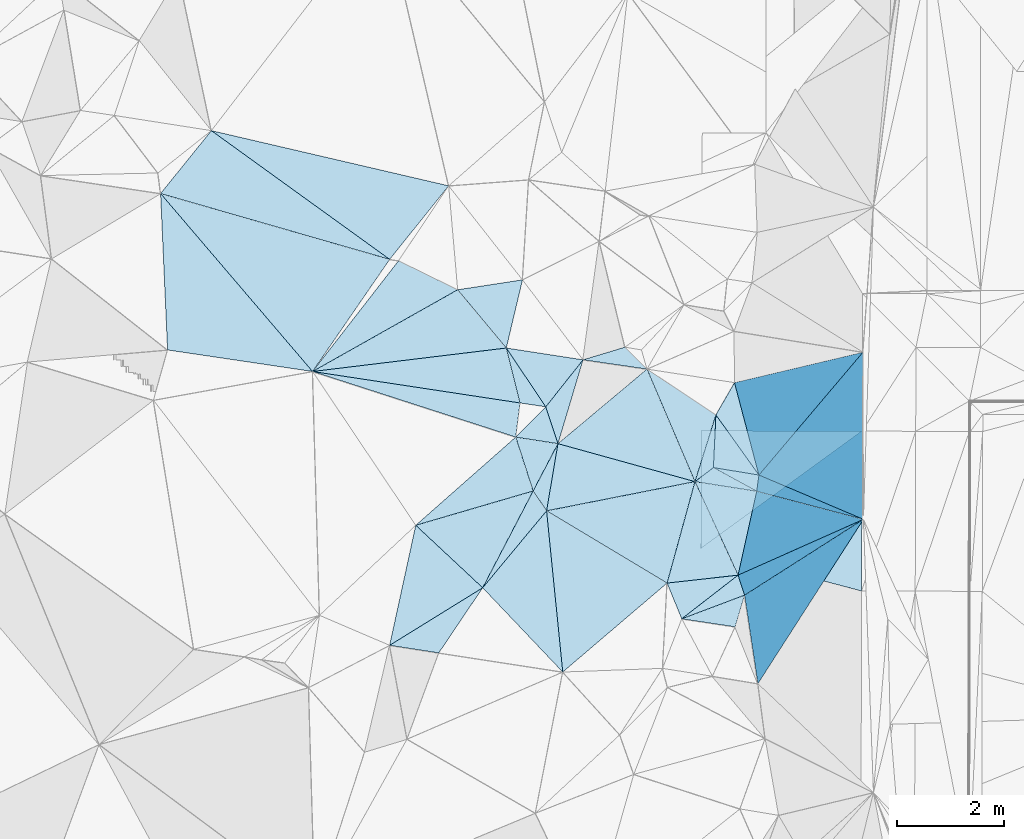
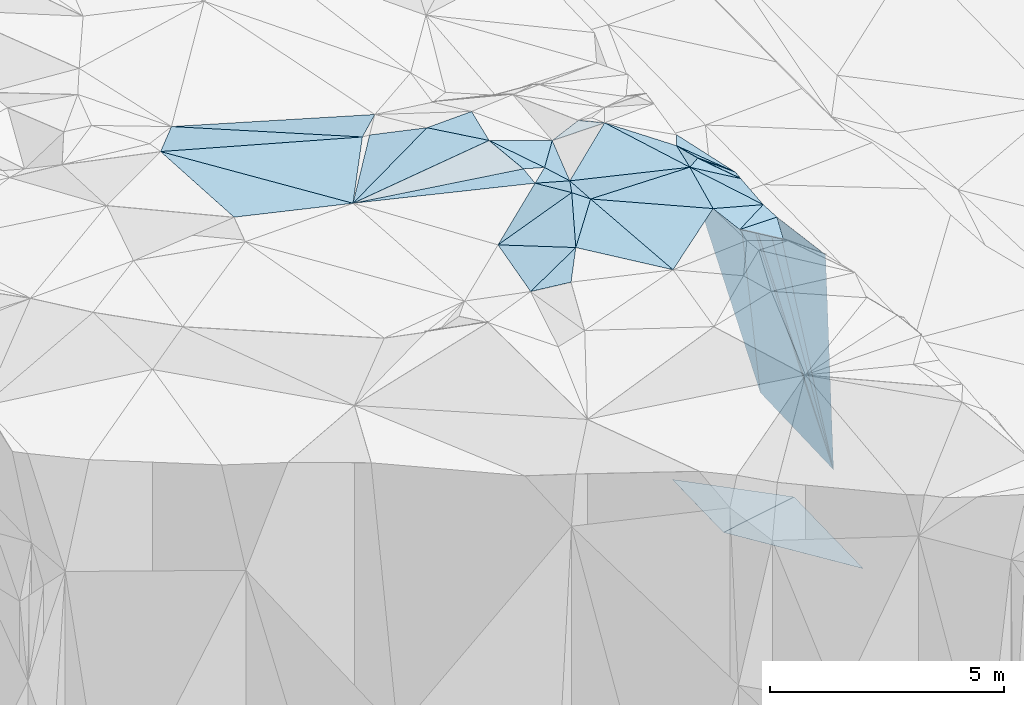
# One storey, part 125 of 275: 45 plates.
"""IFC2X3 building model written with IfcOpenShell, lengths in millimetres."""

import ifcopenshell
import ifcopenshell.guid

model = None  # the IFC model being written
_history = None  # IfcOwnerHistory: only IFC2X3 demands one
_inside = {}  # id of a spatial element -> (the spatial element, [elements in it])
_under = {}  # id of a project, library or spatial element -> (it, [spatial elements below it])
_declared = {}  # id of a project -> (the project, [libraries it declares])
_typed = {}  # id of a type object -> (the type object, [elements of that type])
_made_of = {}  # id of a material, layer set ... -> (it, [elements and type objects made of it])


def new_model(schema):
    """Start an empty IFC model of exactly this schema.

    Asked for "IFC4X3", IfcOpenShell would pick the latest addendum, in which some entities
    have other attributes; the version numbers below select the first issue.
    IFC2X3 requires an IfcOwnerHistory on every rooted entity: one is made here for all.
    """
    global model, _history
    if schema == "IFC4X3":
        model = ifcopenshell.file(schema_version=(4, 3, 0, 0))
    else:
        model = ifcopenshell.file(schema=schema)
    _inside.clear()
    _under.clear()
    _declared.clear()
    _typed.clear()
    _made_of.clear()
    _history = None
    if model.schema == "IFC2X3":
        org = make("IfcOrganization", Name="unknown")
        user = make(
            "IfcPersonAndOrganization",
            ThePerson=make("IfcPerson", FamilyName="unknown"),
            TheOrganization=org,
        )
        app = make(
            "IfcApplication",
            ApplicationDeveloper=org,
            Version="unknown",
            ApplicationFullName="unknown",
            ApplicationIdentifier="unknown",
        )
        _history = make(
            "IfcOwnerHistory",
            OwningUser=user,
            OwningApplication=app,
            ChangeAction="ADDED",
            CreationDate=0,
        )
    return model


def make(cls, **values):
    """One entity of the class cls with the attributes given. An attribute that is None is left unset."""
    return model.create_entity(
        cls, **{name: value for name, value in values.items() if value is not None}
    )


def rooted(cls, **values):
    """An entity with a GlobalId (a new one), such as an element, a storey or a relation."""
    return make(cls, GlobalId=ifcopenshell.guid.new(), OwnerHistory=_history, **values)


def si_unit(unit_type, name, prefix=None):
    """IfcSIUnit, for example si_unit("LENGTHUNIT", "METRE", prefix="MILLI")."""
    return make("IfcSIUnit", UnitType=unit_type, Prefix=prefix, Name=name)


def assignment(units):
    """IfcUnitAssignment: the units of a project."""
    return None if units is None else make("IfcUnitAssignment", Units=units)


def point(xyz):
    """IfcCartesianPoint."""
    return None if xyz is None else make("IfcCartesianPoint", Coordinates=xyz)


def direction(xyz):
    """IfcDirection."""
    return None if xyz is None else make("IfcDirection", DirectionRatios=xyz)


def frame(location, z_axis=None, x_axis=None):
    """IfcAxis2Placement3D, a coordinate frame: its origin and axes. An axis left out is left unset."""
    return make(
        "IfcAxis2Placement3D",
        Location=point(location),
        Axis=direction(z_axis),
        RefDirection=direction(x_axis),
    )


def origin_with_axes():
    """The frame at (0, 0, 0) with the z axis (0, 0, 1) and the x axis (1, 0, 0) written out."""
    return frame((0.0, 0.0, 0.0), z_axis=(0.0, 0.0, 1.0), x_axis=(1.0, 0.0, 0.0))


def place(relative_to, where):
    """IfcLocalPlacement: puts the frame where relative to a parent placement (None: the world)."""
    return make(
        "IfcLocalPlacement", PlacementRelTo=relative_to, RelativePlacement=where
    )


def context(
    kind, dimensions, precision=None, world=None, true_north=None, identifier=None
):
    """IfcGeometricRepresentationContext, for example the 3D "Model" context."""
    return make(
        "IfcGeometricRepresentationContext",
        ContextIdentifier=identifier,
        ContextType=kind,
        CoordinateSpaceDimension=dimensions,
        Precision=precision,
        WorldCoordinateSystem=world,
        TrueNorth=true_north,
    )


def subcontext(parent, identifier, kind, view, scale=None):
    """IfcGeometricRepresentationSubContext, for example "Body" below "Model"."""
    return make(
        "IfcGeometricRepresentationSubContext",
        ContextIdentifier=identifier,
        ContextType=kind,
        ParentContext=parent,
        TargetScale=scale,
        TargetView=view,
    )


def project(units=None, contexts=None):
    """IfcProject with its units and contexts."""
    return rooted(
        "IfcProject",
        Name="project",
        RepresentationContexts=contexts,
        UnitsInContext=assignment(units),
    )


def spatial(cls, under=None, at=None, **own):
    """A site, building, storey or space (cls), placed at a placement, below another one or the project."""
    s = rooted(cls, ObjectPlacement=at, **own)
    if under is not None:
        _under.setdefault(under.id(), (under, []))[1].append(s)
    return s


def polyline(points):
    """IfcPolyline through the points."""
    return make("IfcPolyline", Points=[point(p) for p in points])


def outline(outer, holes=None, kind="AREA"):
    """IfcArbitraryClosedProfileDef: a profile drawn as a closed curve; with holes, ...WithVoids."""
    if holes is None:
        return make("IfcArbitraryClosedProfileDef", ProfileType=kind, OuterCurve=outer)
    return make(
        "IfcArbitraryProfileDefWithVoids",
        ProfileType=kind,
        OuterCurve=outer,
        InnerCurves=holes,
    )


def extrude(swept, where, along, depth):
    """IfcExtrudedAreaSolid: the profile swept, set in the frame where, extruded along a direction by depth."""
    return make(
        "IfcExtrudedAreaSolid",
        SweptArea=swept,
        Position=where,
        ExtrudedDirection=direction(along),
        Depth=depth,
    )


def shape(context_of_items, identifier, shape_type, items):
    """IfcShapeRepresentation: the items that make up one representation, for example the "Body"."""
    return make(
        "IfcShapeRepresentation",
        ContextOfItems=context_of_items,
        RepresentationIdentifier=identifier,
        RepresentationType=shape_type,
        Items=items,
    )


def material(Name=None, Category=None):
    """IfcMaterial."""
    return make("IfcMaterial", Name=Name, Category=Category)


def made_of(thing, what):
    """Note that an element or type object is made of a material, layer set ...; save() writes the relation."""
    if what is not None:
        _made_of.setdefault(what.id(), (what, []))[1].append(thing)
    return thing


def type_object(cls, material=None, **own):
    """A type object (cls), such as IfcWallType, which elements share."""
    return made_of(rooted(cls, **own), material)


def element(
    cls,
    number,
    at=None,
    inside=None,
    cuts=None,
    type_object=None,
    material=None,
    context=None,
    identifier="Body",
    shape_type=None,
    held_by="IfcProductDefinitionShape",
    body=None,
    shapes=None,
    **own,
):
    """One element of the class cls, such as IfcWall. Its Tag is "e" and its number.

    at: its placement. inside: the storey or other place that contains it. cuts: it is an
    opening in that element (IfcRelVoidsElement). A single representation is given by context,
    identifier, shape_type and body (its items); several are given by shapes. held_by: the class
    of the entity that holds the representations. save() writes the other relations.
    """
    e = rooted(cls, Tag="e%d" % number, ObjectPlacement=at, **own)
    if body is not None:
        shapes = [shape(context, identifier, shape_type, body)]
    if shapes is not None:
        e.Representation = make(held_by, Representations=shapes)
    if inside is not None:
        _inside.setdefault(inside.id(), (inside, []))[1].append(e)
    if cuts is not None:
        rooted(
            "IfcRelVoidsElement", RelatingBuildingElement=cuts, RelatedOpeningElement=e
        )
    if type_object is not None:
        _typed.setdefault(type_object.id(), (type_object, []))[1].append(e)
    return made_of(e, material)


def aggregate(whole, parts):
    """IfcRelAggregates: a whole, such as a stair, and the parts it consists of."""
    return rooted("IfcRelAggregates", RelatingObject=whole, RelatedObjects=parts)


def save(model, path):
    """Write the relations noted so far, then the file.

    IfcRelAggregates (storeys below a building ...), IfcRelContainedInSpatialStructure (elements
    in a storey), IfcRelDefinesByType, IfcRelAssociatesMaterial and IfcRelDeclares: one each for
    every whole, place, type object, material and project.
    """
    for whole, parts in _under.values():
        aggregate(whole, parts)
    for where, things in _inside.values():
        rooted(
            "IfcRelContainedInSpatialStructure",
            RelatedElements=things,
            RelatingStructure=where,
        )
    for kind, things in _typed.values():
        rooted("IfcRelDefinesByType", RelatedObjects=things, RelatingType=kind)
    for what, things in _made_of.values():
        rooted("IfcRelAssociatesMaterial", RelatedObjects=things, RelatingMaterial=what)
    for by, libraries in _declared.values():
        rooted("IfcRelDeclares", RelatingContext=by, RelatedDefinitions=libraries)
    model.write(path)


model = new_model("IFC2X3")

# Units and contexts
model_context = context("Model", 3, precision=1e-05, world=origin_with_axes())
body_context = subcontext(model_context, "Body", "Model", "MODEL_VIEW")
ifc_project = project(units=[si_unit("LENGTHUNIT", "METRE", prefix="MILLI"), si_unit("AREAUNIT", "SQUARE_METRE"), si_unit("VOLUMEUNIT", "CUBIC_METRE"), si_unit("MASSUNIT", "GRAM", prefix="KILO"), si_unit("TIMEUNIT", "SECOND"), si_unit("PLANEANGLEUNIT", "RADIAN"), si_unit("SOLIDANGLEUNIT", "STERADIAN"), si_unit("THERMODYNAMICTEMPERATUREUNIT", "DEGREE_CELSIUS"), si_unit("LUMINOUSINTENSITYUNIT", "LUMEN")], contexts=[model_context])

# Site, building, storey
site_placement = place(None, origin_with_axes())
site = spatial("IfcSite", under=ifc_project, at=site_placement, CompositionType="ELEMENT")
building_placement = place(site_placement, origin_with_axes())
building = spatial("IfcBuilding", under=site, at=building_placement, Name="Undefined", CompositionType="ELEMENT")
storey_placement = place(building_placement, origin_with_axes())
storey = spatial("IfcBuildingStorey", under=building, at=storey_placement, Name="Undefined", CompositionType="ELEMENT", Elevation=0.0)

# Plates
ifc_material = material()
plate_type_1 = type_object("IfcPlateType", PredefinedType="NOTDEFINED")
plate_1_placement = place(storey_placement, frame((-101052.780690748, 99922.7773214752, 52409.8605869803), z_axis=(-0.951314452052336, -0.131450359193629, -0.278785968772155), x_axis=(0.256539233213614, 0.163673763012203, -0.952574680076894)))
element("IfcPlate", 1, at=plate_1_placement, inside=storey, type_object=plate_type_1, material=ifc_material, Name="00", context=body_context, shape_type="SweptSolid", body=[
    extrude(outline(polyline([(0.0, 0.0), (8636.5927734375, 2.459273673594e-08), (-139.684707641602, 1664.65856933594), (0.0, 0.0)])), frame((-8.85201319254618e-08, 2.18876761149539e-07, -0.5000001331573), z_axis=(0.0, 0.0, 1.0), x_axis=(1.0, 0.0, 0.0)), (0.0, 0.0, 1.0), 1.0),
])
plate_type_2 = type_object("IfcPlateType", PredefinedType="NOTDEFINED")
plate_2_placement = place(storey_placement, frame((-104994.24122469, 101864.670327626, 53249.5349262964), z_axis=(-0.212168563127397, -0.299815386676256, -0.930104958987223), x_axis=(-0.298590957240027, 0.926146234164656, -0.230426980184854)))
element("IfcPlate", 2, at=plate_2_placement, inside=storey, type_object=plate_type_2, material=ifc_material, Name="00", context=body_context, shape_type="SweptSolid", body=[
    extrude(outline(polyline([(0.0, 0.0), (1084.9423828125, 3.97267285734415e-09), (768.980895996094, 744.021728515625), (0.0, 0.0)])), frame((-8.85201319254618e-08, 2.18876761149539e-07, -0.5000001331573), z_axis=(0.0, 0.0, 1.0), x_axis=(1.0, 0.0, 0.0)), (0.0, 0.0, 1.0), 1.0),
])
plate_type_3 = type_object("IfcPlateType", PredefinedType="NOTDEFINED")
plate_3_placement = place(storey_placement, frame((-101869.450552332, 100790.557702751, 43940.43084673), z_axis=(-0.446999946643608, 0.0202267611373366, -0.894305275526487), x_axis=(0.752863457786508, 0.548428639948646, -0.363899217935159)))
element("IfcPlate", 3, at=plate_3_placement, inside=storey, type_object=plate_type_3, material=ifc_material, Name="00_PR", context=body_context, shape_type="SweptSolid", body=[
    extrude(outline(polyline([(0.0, 0.0), (3993.99047851563, 1.00699253380299e-08), (2375.33764648438, 2503.42431640625), (0.0, 0.0)])), frame((-8.85201319254618e-08, 2.18876761149539e-07, -0.5000001331573), z_axis=(0.0, 0.0, 1.0), x_axis=(1.0, 0.0, 0.0)), (0.0, 0.0, 1.0), 1.0),
])
plate_type_4 = type_object("IfcPlateType", PredefinedType="NOTDEFINED")
plate_4_placement = place(storey_placement, frame((-98862.5211300744, 102980.976509109, 42487.0208652084), z_axis=(-0.447068690798369, 0.0203457226282228, -0.89426821327752), x_axis=(-0.752863457790124, -0.548428639944787, 0.363899217933496)))
element("IfcPlate", 4, at=plate_4_placement, inside=storey, type_object=plate_type_4, material=ifc_material, Name="00_PR", context=body_context, shape_type="SweptSolid", body=[
    extrude(outline(polyline([(0.0, 0.0), (3993.99047851563, 1.00699253380299e-08), (2798.93188476563, 1848.23657226563), (0.0, 0.0)])), frame((-8.85201319254618e-08, 2.18876761149539e-07, -0.5000001331573), z_axis=(0.0, 0.0, 1.0), x_axis=(1.0, 0.0, 0.0)), (0.0, 0.0, 1.0), 1.0),
])
plate_type_5 = type_object("IfcPlateType", PredefinedType="NOTDEFINED")
plate_5_placement = place(storey_placement, frame((-107503.732634978, 106156.509016876, 53029.5030335635), z_axis=(0.0797627524604292, -0.0763591974138967, -0.993884890865256), x_axis=(0.892994833749772, -0.437578966658428, 0.105284732199688)))
element("IfcPlate", 5, at=plate_5_placement, inside=storey, type_object=plate_type_5, material=ifc_material, Name="00", context=body_context, shape_type="SweptSolid", body=[
    extrude(outline(polyline([(0.0, 0.0), (1234.74694824219, 2.16095941141248e-09), (-524.39892578125, 2559.98168945313), (0.0, 0.0)])), frame((-8.85201319254618e-08, 2.18876761149539e-07, -0.5000001331573), z_axis=(0.0, 0.0, 1.0), x_axis=(1.0, 0.0, 0.0)), (0.0, 0.0, 1.0), 1.0),
])
plate_type_6 = type_object("IfcPlateType", PredefinedType="NOTDEFINED")
plate_6_placement = place(storey_placement, frame((-102224.035636845, 99481.5333964225, 52759.5390734306), z_axis=(-0.335199629731002, 0.19468919551731, -0.921811979406333), x_axis=(-0.359367242240399, 0.878023109871996, 0.31611802184507)))
element("IfcPlate", 6, at=plate_6_placement, inside=storey, type_object=plate_type_6, material=ifc_material, Name="00", context=body_context, shape_type="SweptSolid", body=[
    extrude(outline(polyline([(0.0, 0.0), (759.210144042969, -6.40284270048141e-10), (271.071197509766, 1317.99865722656), (0.0, 0.0)])), frame((-8.85201319254618e-08, 2.18876761149539e-07, -0.5000001331573), z_axis=(0.0, 0.0, 1.0), x_axis=(1.0, 0.0, 0.0)), (0.0, 0.0, 1.0), 1.0),
])
plate_type_7 = type_object("IfcPlateType", PredefinedType="NOTDEFINED")
plate_7_placement = place(storey_placement, frame((-102496.778177613, 100147.995579476, 52999.5076277921), z_axis=(-0.149795645728894, -0.08900205802157, -0.984702949212903), x_axis=(-0.854670124604389, 0.512379459087029, 0.0837034528224651)))
element("IfcPlate", 7, at=plate_7_placement, inside=storey, type_object=plate_type_7, material=ifc_material, Name="00", context=body_context, shape_type="SweptSolid", body=[
    extrude(outline(polyline([(0.0, 0.0), (2628.32641601563, 1.01426849141717e-08), (504.275268554688, 1912.12097167969), (0.0, 0.0)])), frame((-8.85201319254618e-08, 2.18876761149539e-07, -0.5000001331573), z_axis=(0.0, 0.0, 1.0), x_axis=(1.0, 0.0, 0.0)), (0.0, 0.0, 1.0), 1.0),
])
plate_type_8 = type_object("IfcPlateType", PredefinedType="NOTDEFINED")
plate_8_placement = place(storey_placement, frame((-105494.585301776, 104530.038624328, 53169.502956674), z_axis=(-0.0790090593919938, -0.0750989410797683, -0.994041104573996), x_axis=(-0.640777609202176, 0.767694014892203, -0.00706788821592721)))
element("IfcPlate", 8, at=plate_8_placement, inside=storey, type_object=plate_type_8, material=ifc_material, Name="00", context=body_context, shape_type="SweptSolid", body=[
    extrude(outline(polyline([(0.0, 0.0), (1414.84985351563, 1.13250280264765e-08), (782.768615722656, 1052.31811523438), (0.0, 0.0)])), frame((-8.85201319254618e-08, 2.18876761149539e-07, -0.5000001331573), z_axis=(0.0, 0.0, 1.0), x_axis=(1.0, 0.0, 0.0)), (0.0, 0.0, 1.0), 1.0),
])
plate_type_9 = type_object("IfcPlateType", PredefinedType="NOTDEFINED")
plate_9_placement = place(storey_placement, frame((-111939.461162771, 107410.06796145, 53389.5039888158), z_axis=(-0.126114466030531, -0.00903749497429484, -0.991974528474609), x_axis=(0.647584047866844, -0.758252184458206, -0.0754223157477399)))
element("IfcPlate", 9, at=plate_9_placement, inside=storey, type_object=plate_type_9, material=ifc_material, Name="00", context=body_context, shape_type="SweptSolid", body=[
    extrude(outline(polyline([(0.0, 0.0), (4375.36279296875, -2.80888343695551e-08), (2294.9638671875, 1804.228515625), (0.0, 0.0)])), frame((-8.85201319254618e-08, 2.18876761149539e-07, -0.5000001331573), z_axis=(0.0, 0.0, 1.0), x_axis=(1.0, 0.0, 0.0)), (0.0, 0.0, 1.0), 1.0),
])
plate_type_10 = type_object("IfcPlateType", PredefinedType="NOTDEFINED")
plate_10_placement = place(storey_placement, frame((-101633.779482135, 102300.81086515, 52709.6041006973), z_axis=(-0.574917464161939, -0.20637256247792, -0.791757712218772), x_axis=(0.0454362008343763, 0.958123261541765, -0.282728433919032)))
element("IfcPlate", 10, at=plate_10_placement, inside=storey, type_object=plate_type_10, material=ifc_material, Name="00", context=body_context, shape_type="SweptSolid", body=[
    extrude(outline(polyline([(0.0, 0.0), (1025.71923828125, -6.51925802230835e-09), (69.6096878051758, 1034.82104492188), (0.0, 0.0)])), frame((-8.85201319254618e-08, 2.18876761149539e-07, -0.5000001331573), z_axis=(0.0, 0.0, 1.0), x_axis=(1.0, 0.0, 0.0)), (0.0, 0.0, 1.0), 1.0),
])
plate_type_11 = type_object("IfcPlateType", PredefinedType="NOTDEFINED")
plate_11_placement = place(storey_placement, frame((-104531.476450295, 102747.258094401, 52859.5017772124), z_axis=(-0.0837255023068137, -0.0131773066483509, -0.996401725637289), x_axis=(-0.313913232321636, 0.949351054200828, 0.0138223898497727)))
element("IfcPlate", 11, at=plate_11_placement, inside=storey, type_object=plate_type_11, material=ifc_material, Name="00", context=body_context, shape_type="SweptSolid", body=[
    extrude(outline(polyline([(0.0, 0.0), (723.4638671875, 1.13504938781261e-09), (1335.79577636719, 938.322814941406), (0.0, 0.0)])), frame((-8.85201319254618e-08, 2.18876761149539e-07, -0.5000001331573), z_axis=(0.0, 0.0, 1.0), x_axis=(1.0, 0.0, 0.0)), (0.0, 0.0, 1.0), 1.0),
])
plate_type_12 = type_object("IfcPlateType", PredefinedType="NOTDEFINED")
plate_12_placement = place(storey_placement, frame((-101977.38174001, 102039.812686806, 52749.5751020443), z_axis=(-0.378138741239032, 0.367324224747449, -0.849755262583202), x_axis=(0.792686433825307, 0.60260897713417, -0.0922531208503361)))
element("IfcPlate", 12, at=plate_12_placement, inside=storey, type_object=plate_type_12, material=ifc_material, Name="00", context=body_context, shape_type="SweptSolid", body=[
    extrude(outline(polyline([(0.0, 0.0), (433.589660644531, 4.94765117764473e-10), (858.415283203125, 984.1357421875), (0.0, 0.0)])), frame((-8.85201319254618e-08, 2.18876761149539e-07, -0.5000001331573), z_axis=(0.0, 0.0, 1.0), x_axis=(1.0, 0.0, 0.0)), (0.0, 0.0, 1.0), 1.0),
])
plate_type_13 = type_object("IfcPlateType", PredefinedType="NOTDEFINED")
plate_13_placement = place(storey_placement, frame((-109106.00025106, 104092.414857728, 53059.5011305136), z_axis=(-0.0346489017911542, -0.0583777233492858, -0.99769308658586), x_axis=(0.988378057486554, -0.149852085824833, -0.0255571487661035)))
element("IfcPlate", 13, at=plate_13_placement, inside=storey, type_object=plate_type_13, material=ifc_material, Name="00", context=body_context, shape_type="SweptSolid", body=[
    extrude(outline(polyline([(0.0, 0.0), (3912.79956054688, 2.66300048679113e-08), (3928.64501953125, 642.455383300781), (0.0, 0.0)])), frame((-8.85201319254618e-08, 2.18876761149539e-07, -0.5000001331573), z_axis=(0.0, 0.0, 1.0), x_axis=(1.0, 0.0, 0.0)), (0.0, 0.0, 1.0), 1.0),
])
plate_type_14 = type_object("IfcPlateType", PredefinedType="NOTDEFINED")
plate_14_placement = place(storey_placement, frame((-102224.062448541, 99481.6157136227, 52759.5758023473), z_axis=(-0.388823327787843, 0.359321869782455, -0.848353825749627), x_axis=(0.901228972809753, 0.339553887122981, -0.269238734783743)))
element("IfcPlate", 14, at=plate_14_placement, inside=storey, type_object=plate_type_14, material=ifc_material, Name="00", context=body_context, shape_type="SweptSolid", body=[
    extrude(outline(polyline([(0.0, 0.0), (1299.96154785156, 5.86442183703184e-09), (986.413818359375, 558.110961914063), (0.0, 0.0)])), frame((-8.85201319254618e-08, 2.18876761149539e-07, -0.5000001331573), z_axis=(0.0, 0.0, 1.0), x_axis=(1.0, 0.0, 0.0)), (0.0, 0.0, 1.0), 1.0),
])
plate_type_15 = type_object("IfcPlateType", PredefinedType="NOTDEFINED")
plate_15_placement = place(storey_placement, frame((-101052.773853434, 99922.7445325661, 52409.8567941893), z_axis=(-0.937641662662594, -0.197026935081731, -0.286371261287906), x_axis=(-0.290924103235318, 0.89569218685578, 0.336301460838689)))
element("IfcPlate", 15, at=plate_15_placement, inside=storey, type_object=plate_type_15, material=ifc_material, Name="00", context=body_context, shape_type="SweptSolid", body=[
    extrude(outline(polyline([(0.0, 0.0), (416.293151855469, -2.43380782194436e-09), (-2145.19506835938, 8365.935546875), (0.0, 0.0)])), frame((-8.85201319254618e-08, 2.18876761149539e-07, -0.5000001331573), z_axis=(0.0, 0.0, 1.0), x_axis=(1.0, 0.0, 0.0)), (0.0, 0.0, 1.0), 1.0),
])
plate_type_16 = type_object("IfcPlateType", PredefinedType="NOTDEFINED")
plate_16_placement = place(storey_placement, frame((-104743.251040852, 101494.644306304, 53219.5500320132), z_axis=(-0.391308095538949, -0.192533484965733, -0.899893789028811), x_axis=(-0.560172426310613, 0.82566761601673, 0.0669316118327603)))
element("IfcPlate", 16, at=plate_16_placement, inside=storey, type_object=plate_type_16, material=ifc_material, Name="00", context=body_context, shape_type="SweptSolid", body=[
    extrude(outline(polyline([(0.0, 0.0), (448.218688964844, -3.17231751978397e-09), (891.529052734375, 973.845947265625), (0.0, 0.0)])), frame((-8.85201319254618e-08, 2.18876761149539e-07, -0.5000001331573), z_axis=(0.0, 0.0, 1.0), x_axis=(1.0, 0.0, 0.0)), (0.0, 0.0, 1.0), 1.0),
])
plate_type_17 = type_object("IfcPlateType", PredefinedType="NOTDEFINED")
plate_17_placement = place(storey_placement, frame((-105494.625096528, 104530.156256097, 53169.5128459579), z_axis=(-0.158604122902922, 0.160170692423395, -0.974263866458571), x_axis=(0.543640945155846, -0.809538144781732, -0.221590872766479)))
element("IfcPlate", 17, at=plate_17_placement, inside=storey, type_object=plate_type_17, material=ifc_material, Name="00", context=body_context, shape_type="SweptSolid", body=[
    extrude(outline(polyline([(0.0, 0.0), (1353.84631347656, -5.37693267688155e-09), (1014.59075927734, 358.755645751953), (0.0, 0.0)])), frame((-8.85201319254618e-08, 2.18876761149539e-07, -0.5000001331573), z_axis=(0.0, 0.0, 1.0), x_axis=(1.0, 0.0, 0.0)), (0.0, 0.0, 1.0), 1.0),
])
plate_type_18 = type_object("IfcPlateType", PredefinedType="NOTDEFINED")
plate_18_placement = place(storey_placement, frame((-103282.006128294, 104546.055906759, 52909.504466475), z_axis=(0.129541275132308, 0.0330692780375528, -0.991022442171302), x_axis=(0.706664030143269, -0.704189176832656, 0.0688734472305546)))
element("IfcPlate", 18, at=plate_18_placement, inside=storey, type_object=plate_type_18, material=ifc_material, Name="00", context=body_context, shape_type="SweptSolid", body=[
    extrude(outline(polyline([(0.0, 0.0), (580.775329589844, -9.6588337328285e-10), (-393.439575195313, 723.467529296875), (0.0, 0.0)])), frame((-8.85201319254618e-08, 2.18876761149539e-07, -0.5000001331573), z_axis=(0.0, 0.0, 1.0), x_axis=(1.0, 0.0, 0.0)), (0.0, 0.0, 1.0), 1.0),
])
plate_type_19 = type_object("IfcPlateType", PredefinedType="NOTDEFINED")
plate_19_placement = place(storey_placement, frame((-104531.52556011, 102747.241751831, 52859.5088587508), z_axis=(-0.181941880242754, -0.0458598214129536, -0.982239293142818), x_axis=(-0.973182946861914, 0.151386964760187, 0.173196243717521)))
element("IfcPlate", 19, at=plate_19_placement, inside=storey, type_object=plate_type_19, material=ifc_material, Name="00", context=body_context, shape_type="SweptSolid", body=[
    extrude(outline(polyline([(0.0, 0.0), (808.331604003906, -4.86033968627453e-09), (326.722351074219, 645.486267089844), (0.0, 0.0)])), frame((-8.85201319254618e-08, 2.18876761149539e-07, -0.5000001331573), z_axis=(0.0, 0.0, 1.0), x_axis=(1.0, 0.0, 0.0)), (0.0, 0.0, 1.0), 1.0),
])
plate_type_20 = type_object("IfcPlateType", PredefinedType="NOTDEFINED")
plate_20_placement = place(storey_placement, frame((-105318.014394748, 102869.539013006, 52999.5151130951), z_axis=(0.14947784813316, -0.193078901508615, -0.969730328859372), x_axis=(0.298590957251991, -0.926146234156539, 0.230426980201975)))
element("IfcPlate", 20, at=plate_20_placement, inside=storey, type_object=plate_type_20, material=ifc_material, Name="00", context=body_context, shape_type="SweptSolid", body=[
    extrude(outline(polyline([(0.0, 0.0), (1084.9423828125, 3.97267285734415e-09), (975.351318359375, 2286.8515625), (0.0, 0.0)])), frame((-8.85201319254618e-08, 2.18876761149539e-07, -0.5000001331573), z_axis=(0.0, 0.0, 1.0), x_axis=(1.0, 0.0, 0.0)), (0.0, 0.0, 1.0), 1.0),
])
plate_type_21 = type_object("IfcPlateType", PredefinedType="NOTDEFINED")
plate_21_placement = place(storey_placement, frame((-104994.166571093, 101864.839363382, 53249.5013263234), z_axis=(-0.062776416840885, 0.0382537617920036, -0.997294224989486), x_axis=(0.560172426649002, -0.825667615778907, -0.0669316119344513)))
element("IfcPlate", 21, at=plate_21_placement, inside=storey, type_object=plate_type_21, material=ifc_material, Name="00", context=body_context, shape_type="SweptSolid", body=[
    extrude(outline(polyline([(0.0, 0.0), (448.218688964844, -3.17231751978397e-09), (963.592102050781, 1792.36999511719), (0.0, 0.0)])), frame((-8.85201319254618e-08, 2.18876761149539e-07, -0.5000001331573), z_axis=(0.0, 0.0, 1.0), x_axis=(1.0, 0.0, 0.0)), (0.0, 0.0, 1.0), 1.0),
])
plate_type_22 = type_object("IfcPlateType", PredefinedType="NOTDEFINED")
plate_22_placement = place(storey_placement, frame((-100826.622726777, 101859.736579014, 52159.8763853822), z_axis=(-0.963076611302478, 0.106682236598099, -0.247188877493633), x_axis=(0.134333623769339, 0.986098465781905, -0.097797205008998)))
element("IfcPlate", 22, at=plate_22_placement, inside=storey, type_object=plate_type_22, material=ifc_material, Name="00", context=body_context, shape_type="SweptSolid", body=[
    extrude(outline(polyline([(0.0, 0.0), (306.757232666016, -1.55705492943525e-09), (531.397399902344, 8220.8212890625), (0.0, 0.0)])), frame((-8.85201319254618e-08, 2.18876761149539e-07, -0.5000001331573), z_axis=(0.0, 0.0, 1.0), x_axis=(1.0, 0.0, 0.0)), (0.0, 0.0, 1.0), 1.0),
])
plate_type_23 = type_object("IfcPlateType", PredefinedType="NOTDEFINED")
plate_23_placement = place(storey_placement, frame((-101173.59263188, 100295.826093651, 52549.5464399137), z_axis=(-0.355767882138034, 0.225022474354415, -0.90707998548884), x_axis=(0.290924103230052, -0.895692186858166, -0.336301460836892)))
element("IfcPlate", 23, at=plate_23_placement, inside=storey, type_object=plate_type_23, material=ifc_material, Name="00", context=body_context, shape_type="SweptSolid", body=[
    extrude(outline(polyline([(0.0, 0.0), (416.293151855469, -2.43380782194436e-09), (353.116546630859, 1298.42541503906), (0.0, 0.0)])), frame((-8.85201319254618e-08, 2.18876761149539e-07, -0.5000001331573), z_axis=(0.0, 0.0, 1.0), x_axis=(1.0, 0.0, 0.0)), (0.0, 0.0, 1.0), 1.0),
])
plate_type_24 = type_object("IfcPlateType", PredefinedType="NOTDEFINED")
plate_24_placement = place(storey_placement, frame((-100785.141125361, 102162.144845936, 52129.5462547157), z_axis=(-0.415493483113326, -0.0624575036943869, -0.907449296502357), x_axis=(-0.569205550226153, 0.796013368880845, 0.205834297809453)))
element("IfcPlate", 24, at=plate_24_placement, inside=storey, type_object=plate_type_24, material=ifc_material, Name="00", context=body_context, shape_type="SweptSolid", body=[
    extrude(outline(polyline([(0.0, 0.0), (1408.90026855469, 5.4860720410943e-09), (1649.30053710938, 681.107727050781), (0.0, 0.0)])), frame((-8.85201319254618e-08, 2.18876761149539e-07, -0.5000001331573), z_axis=(0.0, 0.0, 1.0), x_axis=(1.0, 0.0, 0.0)), (0.0, 0.0, 1.0), 1.0),
])
plate_type_25 = type_object("IfcPlateType", PredefinedType="NOTDEFINED")
plate_25_placement = place(storey_placement, frame((-104531.490841846, 102747.13624316, 52859.5200417725), z_axis=(-0.112503921357946, -0.256878218408387, -0.95987314192367), x_axis=(0.96287132298201, -0.266757066765258, -0.0414666457489527)))
element("IfcPlate", 25, at=plate_25_placement, inside=storey, type_object=plate_type_25, material=ifc_material, Name="00", context=body_context, shape_type="SweptSolid", body=[
    extrude(outline(polyline([(0.0, 0.0), (2652.734375, -5.79166226089001e-09), (115.428062438965, 1315.24768066406), (0.0, 0.0)])), frame((-8.85201319254618e-08, 2.18876761149539e-07, -0.5000001331573), z_axis=(0.0, 0.0, 1.0), x_axis=(1.0, 0.0, 0.0)), (0.0, 0.0, 1.0), 1.0),
])
plate_type_26 = type_object("IfcPlateType", PredefinedType="NOTDEFINED")
plate_26_placement = place(storey_placement, frame((-100785.39679268, 102162.061304729, 52129.8514202319), z_axis=(-0.92683936649606, -0.229543090334693, -0.297117415162393), x_axis=(-0.255297878268721, 0.96554601309584, 0.0504369898607854)))
element("IfcPlate", 26, at=plate_26_placement, inside=storey, type_object=plate_type_26, material=ifc_material, Name="00", context=body_context, shape_type="SweptSolid", body=[
    extrude(outline(polyline([(0.0, 0.0), (1784.40466308594, -5.05679054185748e-09), (1321.33703613281, 8271.189453125), (0.0, 0.0)])), frame((-8.85201319254618e-08, 2.18876761149539e-07, -0.5000001331573), z_axis=(0.0, 0.0, 1.0), x_axis=(1.0, 0.0, 0.0)), (0.0, 0.0, 1.0), 1.0),
])
plate_type_27 = type_object("IfcPlateType", PredefinedType="NOTDEFINED")
plate_27_placement = place(storey_placement, frame((-105934.78892645, 100060.336780118, 53239.5037215378), z_axis=(0.110466316561426, -0.0520885219837571, -0.992513969061846), x_axis=(-0.725917048312284, 0.677866181999279, -0.116369576227213)))
element("IfcPlate", 27, at=plate_27_placement, inside=storey, type_object=plate_type_27, material=ifc_material, Name="00", context=body_context, shape_type="SweptSolid", body=[
    extrude(outline(polyline([(0.0, 0.0), (1718.66223144531, -8.57562554301694e-09), (539.140258789063, 1962.25073242188), (0.0, 0.0)])), frame((-8.85201319254618e-08, 2.18876761149539e-07, -0.5000001331573), z_axis=(0.0, 0.0, 1.0), x_axis=(1.0, 0.0, 0.0)), (0.0, 0.0, 1.0), 1.0),
])
plate_type_28 = type_object("IfcPlateType", PredefinedType="NOTDEFINED")
plate_28_placement = place(storey_placement, frame((-101633.774437963, 102300.911604278, 52709.5873830905), z_axis=(-0.564829532149485, -0.00489401551544607, -0.825193097537739), x_axis=(0.818156298329736, -0.133767240893072, -0.559219631957999)))
element("IfcPlate", 28, at=plate_28_placement, inside=storey, type_object=plate_type_28, material=ifc_material, Name="00", context=body_context, shape_type="SweptSolid", body=[
    extrude(outline(polyline([(0.0, 0.0), (1037.15954589844, 3.02679836750031e-09), (1027.13220214844, 306.593292236328), (0.0, 0.0)])), frame((-8.85201319254618e-08, 2.18876761149539e-07, -0.5000001331573), z_axis=(0.0, 0.0, 1.0), x_axis=(1.0, 0.0, 0.0)), (0.0, 0.0, 1.0), 1.0),
])
plate_type_29 = type_object("IfcPlateType", PredefinedType="NOTDEFINED")
plate_29_placement = place(storey_placement, frame((-104743.093548845, 101494.758306789, 53219.5017526815), z_axis=(-0.0763251026656692, 0.0354691828443142, -0.996451913426549), x_axis=(0.85467012459467, -0.512379459103205, -0.0837034528226824)))
element("IfcPlate", 29, at=plate_29_placement, inside=storey, type_object=plate_type_29, material=ifc_material, Name="00", context=body_context, shape_type="SweptSolid", body=[
    extrude(outline(polyline([(0.0, 0.0), (2628.32641601563, 1.01426849141717e-08), (1807.61413574219, 2422.79418945313), (0.0, 0.0)])), frame((-8.85201319254618e-08, 2.18876761149539e-07, -0.5000001331573), z_axis=(0.0, 0.0, 1.0), x_axis=(1.0, 0.0, 0.0)), (0.0, 0.0, 1.0), 1.0),
])
plate_type_30 = type_object("IfcPlateType", PredefinedType="NOTDEFINED")
plate_30_placement = place(storey_placement, frame((-107669.121684265, 98987.4274576751, 53349.5052519899), z_axis=(0.0254566304773288, -0.142598711158138, -0.98945316591579), x_axis=(0.210587081769812, 0.968328731725895, -0.134136304950576)))
element("IfcPlate", 30, at=plate_30_placement, inside=storey, type_object=plate_type_30, material=ifc_material, Name="00", context=body_context, shape_type="SweptSolid", body=[
    extrude(outline(polyline([(0.0, 0.0), (2311.08203125, -1.04628270491958e-08), (1418.85925292969, 1468.92431640625), (0.0, 0.0)])), frame((-8.85201319254618e-08, 2.18876761149539e-07, -0.5000001331573), z_axis=(0.0, 0.0, 1.0), x_axis=(1.0, 0.0, 0.0)), (0.0, 0.0, 1.0), 1.0),
])
plate_type_31 = type_object("IfcPlateType", PredefinedType="NOTDEFINED")
plate_31_placement = place(storey_placement, frame((-101977.351632829, 102039.610076782, 52749.5263014844), z_axis=(-0.317931530007672, -0.0378889258869294, -0.947356306529975), x_axis=(0.416331140967923, -0.903292174395285, -0.103593574784273)))
element("IfcPlate", 31, at=plate_31_placement, inside=storey, type_object=plate_type_31, material=ifc_material, Name="00", context=body_context, shape_type="SweptSolid", body=[
    extrude(outline(polyline([(0.0, 0.0), (1930.62170410156, -5.96628524363041e-09), (1466.470703125, 1326.63623046875), (0.0, 0.0)])), frame((-8.85201319254618e-08, 2.18876761149539e-07, -0.5000001331573), z_axis=(0.0, 0.0, 1.0), x_axis=(1.0, 0.0, 0.0)), (0.0, 0.0, 1.0), 1.0),
])
plate_type_32 = type_object("IfcPlateType", PredefinedType="NOTDEFINED")
plate_32_placement = place(storey_placement, frame((-105934.846136436, 100060.31499311, 53239.5022758924), z_axis=(-0.00395607601283091, -0.0956632504760156, -0.995405893076259), x_axis=(-0.557020143006779, -0.826476332367151, 0.0816420989542246)))
element("IfcPlate", 32, at=plate_32_placement, inside=storey, type_object=plate_type_32, material=ifc_material, Name="00", context=body_context, shape_type="SweptSolid", body=[
    extrude(outline(polyline([(0.0, 0.0), (1469.82995605469, 2.18278728425503e-09), (1861.71203613281, 839.600158691406), (0.0, 0.0)])), frame((-8.85201319254618e-08, 2.18876761149539e-07, -0.5000001331573), z_axis=(0.0, 0.0, 1.0), x_axis=(1.0, 0.0, 0.0)), (0.0, 0.0, 1.0), 1.0),
])
plate_type_33 = type_object("IfcPlateType", PredefinedType="NOTDEFINED")
plate_33_placement = place(storey_placement, frame((-101977.202072424, 102039.672503109, 52749.5019623024), z_axis=(-0.0188038683277279, 0.086957419672698, -0.99603454844688), x_axis=(-0.962871322983523, 0.266757066759082, 0.0414666457535608)))
element("IfcPlate", 33, at=plate_33_placement, inside=storey, type_object=plate_type_33, material=ifc_material, Name="00", context=body_context, shape_type="SweptSolid", body=[
    extrude(outline(polyline([(0.0, 0.0), (2652.734375, -5.79166226089001e-09), (1429.0537109375, 1788.04516601563), (0.0, 0.0)])), frame((-8.85201319254618e-08, 2.18876761149539e-07, -0.5000001331573), z_axis=(0.0, 0.0, 1.0), x_axis=(1.0, 0.0, 0.0)), (0.0, 0.0, 1.0), 1.0),
])
plate_type_34 = type_object("IfcPlateType", PredefinedType="NOTDEFINED")
plate_34_placement = place(storey_placement, frame((-101173.893184635, 100295.788835433, 52549.8757225867), z_axis=(-0.956865366100951, 0.15049756737197, -0.248513889695551), x_axis=(0.210615863773851, 0.948522588705582, -0.236528764935801)))
element("IfcPlate", 34, at=plate_34_placement, inside=storey, type_object=plate_type_34, material=ifc_material, Name="00", context=body_context, shape_type="SweptSolid", body=[
    extrude(outline(polyline([(0.0, 0.0), (1648.84802246094, 1.0710209608078e-08), (3458.32958984375, 8036.7939453125), (0.0, 0.0)])), frame((-8.85201319254618e-08, 2.18876761149539e-07, -0.5000001331573), z_axis=(0.0, 0.0, 1.0), x_axis=(1.0, 0.0, 0.0)), (0.0, 0.0, 1.0), 1.0),
])
plate_type_35 = type_object("IfcPlateType", PredefinedType="NOTDEFINED")
plate_35_placement = place(storey_placement, frame((-104442.350645506, 98489.7535559699, 53089.5012620663), z_axis=(-0.0612894983866445, 0.0370163776948662, -0.997433398864237), x_axis=(-0.687208357353394, 0.72316989204192, 0.0690650478008059)))
element("IfcPlate", 35, at=plate_35_placement, inside=storey, type_object=plate_type_35, material=ifc_material, Name="00", context=body_context, shape_type="SweptSolid", body=[
    extrude(outline(polyline([(0.0, 0.0), (2171.86547851563, 1.43554643727839e-08), (2388.77587890625, 1852.33630371094), (0.0, 0.0)])), frame((-8.85201319254618e-08, 2.18876761149539e-07, -0.5000001331573), z_axis=(0.0, 0.0, 1.0), x_axis=(1.0, 0.0, 0.0)), (0.0, 0.0, 1.0), 1.0),
])
plate_type_36 = type_object("IfcPlateType", PredefinedType="NOTDEFINED")
plate_36_placement = place(storey_placement, frame((-104758.65609948, 103434.139838045, 52869.5167715471), z_axis=(-0.233247350972345, 0.107895480622811, -0.966413078618846), x_axis=(-0.543640945164597, 0.809538144773453, 0.221590872775258)))
element("IfcPlate", 36, at=plate_36_placement, inside=storey, type_object=plate_type_36, material=ifc_material, Name="00", context=body_context, shape_type="SweptSolid", body=[
    extrude(outline(polyline([(0.0, 0.0), (1353.84631347656, -5.37693267688155e-09), (315.619262695313, 1075.07421875), (0.0, 0.0)])), frame((-8.85201319254618e-08, 2.18876761149539e-07, -0.5000001331573), z_axis=(0.0, 0.0, 1.0), x_axis=(1.0, 0.0, 0.0)), (0.0, 0.0, 1.0), 1.0),
])
plate_type_37 = type_object("IfcPlateType", PredefinedType="NOTDEFINED")
plate_37_placement = place(storey_placement, frame((-101173.648393766, 100295.656167326, 52549.5616708065), z_axis=(-0.467284681820828, -0.114839140835068, -0.87661679077455), x_axis=(-0.416331140168813, 0.903292174760844, 0.103593574808296)))
element("IfcPlate", 37, at=plate_37_placement, inside=storey, type_object=plate_type_37, material=ifc_material, Name="00", context=body_context, shape_type="SweptSolid", body=[
    extrude(outline(polyline([(0.0, 0.0), (1930.62170410156, -5.96628524363041e-09), (1227.7392578125, 1100.61633300781), (0.0, 0.0)])), frame((-8.85201319254618e-08, 2.18876761149539e-07, -0.5000001331573), z_axis=(0.0, 0.0, 1.0), x_axis=(1.0, 0.0, 0.0)), (0.0, 0.0, 1.0), 1.0),
])
plate_type_38 = type_object("IfcPlateType", PredefinedType="NOTDEFINED")
plate_38_placement = place(storey_placement, frame((-109105.968590786, 104092.451406694, 53059.5002368612), z_axis=(0.0286592852371685, 0.0147194179642042, -0.999480857297672), x_axis=(0.870802295819946, 0.490578116157436, 0.0321943091575539)))
element("IfcPlate", 38, at=plate_38_placement, inside=storey, type_object=plate_type_38, material=ifc_material, Name="00", context=body_context, shape_type="SweptSolid", body=[
    extrude(outline(polyline([(0.0, 0.0), (3106.13916015625, -3.11410985887051e-09), (3363.08178710938, 1391.3232421875), (0.0, 0.0)])), frame((-8.85201319254618e-08, 2.18876761149539e-07, -0.5000001331573), z_axis=(0.0, 0.0, 1.0), x_axis=(1.0, 0.0, 0.0)), (0.0, 0.0, 1.0), 1.0),
])
plate_type_39 = type_object("IfcPlateType", PredefinedType="NOTDEFINED")
plate_39_placement = place(storey_placement, frame((-101586.833913533, 103283.536507353, 52419.5238485186), z_axis=(0.106638109390486, -0.286055496840188, -0.952260765942363), x_axis=(-0.0454362008294118, -0.958123261535516, 0.282728433941007)))
element("IfcPlate", 39, at=plate_39_placement, inside=storey, type_object=plate_type_39, material=ifc_material, Name="00", context=body_context, shape_type="SweptSolid", body=[
    extrude(outline(polyline([(0.0, 0.0), (1025.71923828125, -6.51925802230835e-09), (1302.98815917969, 333.349639892578), (0.0, 0.0)])), frame((-8.85201319254618e-08, 2.18876761149539e-07, -0.5000001331573), z_axis=(0.0, 0.0, 1.0), x_axis=(1.0, 0.0, 0.0)), (0.0, 0.0, 1.0), 1.0),
])
plate_type_40 = type_object("IfcPlateType", PredefinedType="NOTDEFINED")
plate_40_placement = place(storey_placement, frame((-101977.410546114, 102039.578753506, 52749.5527638437), z_axis=(-0.435759419242234, -0.100544581120343, -0.89442971537679), x_axis=(-0.390775032060947, 0.916329780531374, 0.0873762417885435)))
element("IfcPlate", 40, at=plate_40_placement, inside=storey, type_object=plate_type_40, material=ifc_material, Name="00", context=body_context, shape_type="SweptSolid", body=[
    extrude(outline(polyline([(0.0, 0.0), (2288.95166015625, 1.18016032502055e-08), (958.604736328125, 943.385864257813), (0.0, 0.0)])), frame((-8.85201319254618e-08, 2.18876761149539e-07, -0.5000001331573), z_axis=(0.0, 0.0, 1.0), x_axis=(1.0, 0.0, 0.0)), (0.0, 0.0, 1.0), 1.0),
])
plate_type_41 = type_object("IfcPlateType", PredefinedType="NOTDEFINED")
plate_41_placement = place(storey_placement, frame((-98845.6696752361, 104452.042707349, 44309.8805816706), z_axis=(-0.971044598611189, 0.00708331604606218, -0.23879324559507), x_axis=(0.00272724124547423, -0.999166529325054, -0.0407284769137734)))
element("IfcPlate", 41, at=plate_41_placement, inside=storey, type_object=plate_type_41, material=ifc_material, Name="00", context=body_context, shape_type="SweptSolid", body=[
    extrude(outline(polyline([(0.0, 0.0), (3118.21142578125, 6.54836185276508e-11), (1964.16772460938, 8142.5146484375), (0.0, 0.0)])), frame((-8.85201319254618e-08, 2.18876761149539e-07, -0.5000001331573), z_axis=(0.0, 0.0, 1.0), x_axis=(1.0, 0.0, 0.0)), (0.0, 0.0, 1.0), 1.0),
])
plate_type_42 = type_object("IfcPlateType", PredefinedType="NOTDEFINED")
plate_42_placement = place(storey_placement, frame((-107668.280022722, 106182.150580255, 53019.5159986878), z_axis=(-0.143160320444688, -0.206318182857618, -0.967955541371867), x_axis=(-0.957764554443284, 0.27532405889009, 0.082968191786635)))
element("IfcPlate", 42, at=plate_42_placement, inside=storey, type_object=plate_type_42, material=ifc_material, Name="00", context=body_context, shape_type="SweptSolid", body=[
    extrude(outline(polyline([(0.0, 0.0), (4459.54052734375, 3.21597326546907e-09), (3843.5126953125, 1429.79370117188), (0.0, 0.0)])), frame((-8.85201319254618e-08, 2.18876761149539e-07, -0.5000001331573), z_axis=(0.0, 0.0, 1.0), x_axis=(1.0, 0.0, 0.0)), (0.0, 0.0, 1.0), 1.0),
])
plate_type_43 = type_object("IfcPlateType", PredefinedType="NOTDEFINED")
plate_43_placement = place(storey_placement, frame((-111939.436433805, 107410.089313545, 53389.5017297549), z_axis=(-0.0766469835758482, 0.0336592750658611, -0.996489986457849), x_axis=(0.95776455444243, -0.275324058894702, -0.0829681917811844)))
element("IfcPlate", 43, at=plate_43_placement, inside=storey, type_object=plate_type_43, material=ifc_material, Name="00", context=body_context, shape_type="SweptSolid", body=[
    extrude(outline(polyline([(0.0, 0.0), (4459.54052734375, 3.21597326546907e-09), (3654.54711914063, 2405.84399414063), (0.0, 0.0)])), frame((-8.85201319254618e-08, 2.18876761149539e-07, -0.5000001331573), z_axis=(0.0, 0.0, 1.0), x_axis=(1.0, 0.0, 0.0)), (0.0, 0.0, 1.0), 1.0),
])
plate_type_44 = type_object("IfcPlateType", PredefinedType="NOTDEFINED")
plate_44_placement = place(storey_placement, frame((-110992.918663967, 108582.833497416, 52999.5294038857), z_axis=(-0.194137938199628, -0.27669072331297, -0.941144359056645), x_axis=(0.965326529405432, -0.224560118838649, -0.133106891832225)))
element("IfcPlate", 44, at=plate_44_placement, inside=storey, type_object=plate_type_44, material=ifc_material, Name="00", context=body_context, shape_type="SweptSolid", body=[
    extrude(outline(polyline([(0.0, 0.0), (4582.783203125, 5.45696821063757e-09), (3745.78076171875, 1669.1396484375), (0.0, 0.0)])), frame((-8.85201319254618e-08, 2.18876761149539e-07, -0.5000001331573), z_axis=(0.0, 0.0, 1.0), x_axis=(1.0, 0.0, 0.0)), (0.0, 0.0, 1.0), 1.0),
])
plate_type_45 = type_object("IfcPlateType", PredefinedType="NOTDEFINED")
plate_45_placement = place(storey_placement, frame((-105494.543133357, 104530.177265915, 53169.5103100325), z_axis=(0.00532961499274524, 0.202177168584622, -0.9793344616152), x_axis=(0.23778090537704, -0.951514912177616, -0.195139982939679)))
element("IfcPlate", 45, at=plate_45_placement, inside=storey, type_object=plate_type_45, material=ifc_material, Name="00", context=body_context, shape_type="SweptSolid", body=[
    extrude(outline(polyline([(0.0, 0.0), (1076.15051269531, 8.45466274768114e-09), (-420.851898193359, 3615.10498046875), (0.0, 0.0)])), frame((-8.85201319254618e-08, 2.18876761149539e-07, -0.5000001331573), z_axis=(0.0, 0.0, 1.0), x_axis=(1.0, 0.0, 0.0)), (0.0, 0.0, 1.0), 1.0),
])

save(model, "model.ifc")
